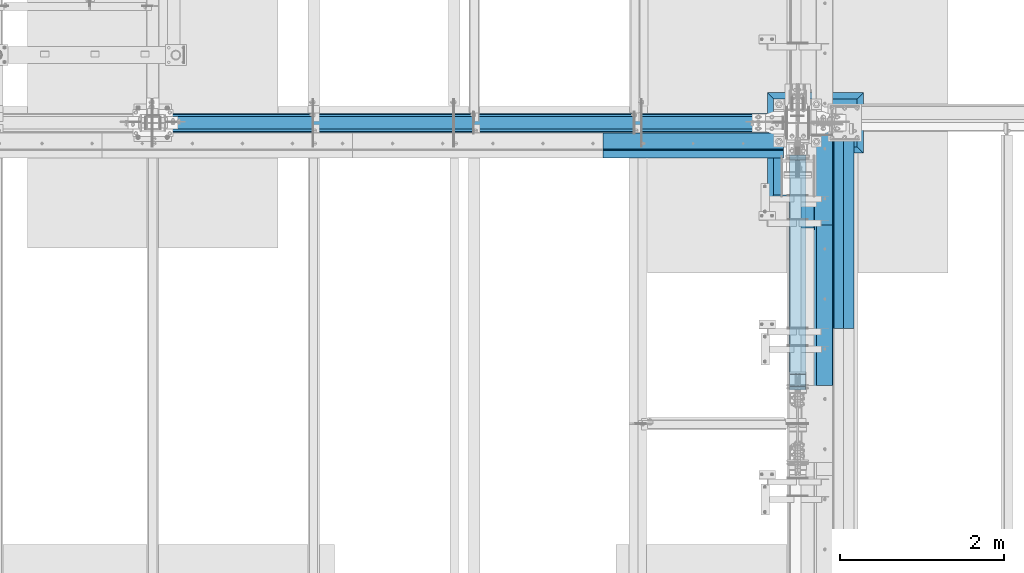
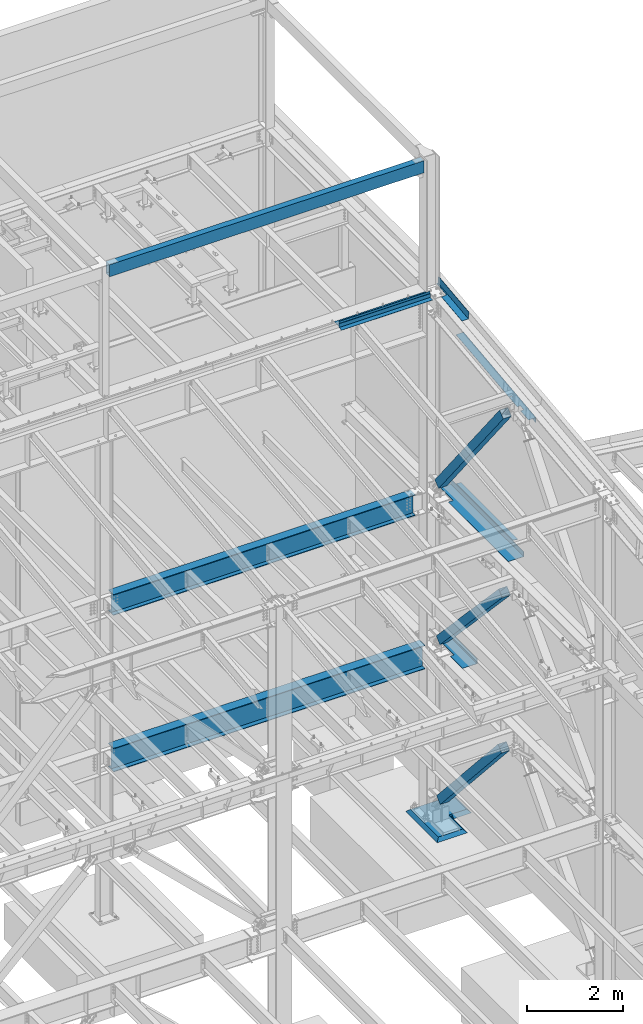
# One storey, part 775 of 1179: 12 beams, 3 members, 14 elements without a shape of their own.
"""IFC2X3 building model written with IfcOpenShell, lengths in millimetres."""

from ifc_helpers import new_model, si_unit, frame, origin_with_axes, place, context, subcontext, project, spatial, faceted_brep, material, type_object, element, aggregate, save


model = new_model("IFC2X3")

# Units and contexts
model_context = context("Model", 3, precision=1e-05, world=origin_with_axes())
body_context = subcontext(model_context, "Body", "Model", "MODEL_VIEW")
ifc_project = project(units=[si_unit("LENGTHUNIT", "METRE", prefix="MILLI"), si_unit("AREAUNIT", "SQUARE_METRE"), si_unit("VOLUMEUNIT", "CUBIC_METRE"), si_unit("MASSUNIT", "GRAM", prefix="KILO"), si_unit("TIMEUNIT", "SECOND"), si_unit("PLANEANGLEUNIT", "RADIAN"), si_unit("SOLIDANGLEUNIT", "STERADIAN"), si_unit("THERMODYNAMICTEMPERATUREUNIT", "DEGREE_CELSIUS"), si_unit("LUMINOUSINTENSITYUNIT", "LUMEN")], contexts=[model_context])

# Site, building, storey
site_placement = place(None, origin_with_axes())
site = spatial("IfcSite", under=ifc_project, at=site_placement, CompositionType="ELEMENT")
building_placement = place(site_placement, origin_with_axes())
building = spatial("IfcBuilding", under=site, at=building_placement, Name="Undefined", CompositionType="ELEMENT")
storey_placement = place(building_placement, origin_with_axes())
storey = spatial("IfcBuildingStorey", under=building, at=storey_placement, Name="Undefined", CompositionType="ELEMENT", Elevation=0.0)

# Assembly, beam
assembly_1_placement = place(storey_placement, origin_with_axes())
assembly_1 = element("IfcElementAssembly", 1, at=assembly_1_placement, inside=storey, Name="BEAM", AssemblyPlace="NOTDEFINED", PredefinedType="RIGID_FRAME")
ifc_material_1 = material(Name="STEEL/A36")
beam_type_1 = type_object("IfcBeamType", PredefinedType="NOTDEFINED")
beam_1_placement = place(assembly_1_placement, frame((24350.6630000112, 33750.8239309392, 13063.8736849896), z_axis=(0.0, -0.993676146336441, -0.112284087038017), x_axis=(1.0, 0.0, 0.0)))
beam_1 = element("IfcBeam", 2, at=beam_1_placement, type_object=beam_type_1, material=ifc_material_1, Name="BENT_PLATE", context=body_context, shape_type="Brep", body=[
    faceted_brep([(125.411064157626, -3.25796124146109, -222.2233852844), (125.411083925232, 3.17499999981919, -222.223388638246), (125.411548813434, 3.1749999994754, -643.731500001937), (125.411529045858, -3.17500000052132, -643.731500001937), (5.14432940690313e-11, -3.17499999981919, -222.223406928701), (5.14432940690313e-11, 3.17500000017753, -222.223410238686), (153.98699999888, 3.17500000052314, 643.731500002003), (-1.48986600834178e-10, 3.17499999947358, 643.731500001959), (-1.48986600834178e-10, -3.17500000052314, 643.731500001952), (160.336999998879, -3.17499999947358, 643.73150000201), (160.336999999035, 187.325000001743, 643.731500001973), (153.986999999037, 187.325000001743, 643.731500001973), (153.986999999484, 3.1749999994754, -643.73150000193), (153.986999999328, 187.325000000987, -643.731500001966), (160.336999999327, 187.325000000988, -643.731500001959), (160.336999999483, -3.17500000052132, -643.73150000193)], [[[0, 1, 2, 3]], [[4, 5, 1, 0]], [[6, 7, 8, 9, 10, 11]], [[12, 6, 11, 13]], [[10, 14, 13, 11]], [[9, 15, 14, 10]], [[12, 13, 14, 15, 3, 2]], [[7, 6, 12, 2, 1, 5]], [[8, 7, 5, 4]], [[15, 9, 8, 4, 0, 3]]]),
])

assembly_2_placement = place(storey_placement, origin_with_axes())
assembly_2 = element("IfcElementAssembly", 3, at=assembly_2_placement, inside=storey, Name="BENT_PLATE", AssemblyPlace="NOTDEFINED", PredefinedType="RIGID_FRAME")
beam_type_2 = type_object("IfcBeamType", PredefinedType="NOTDEFINED")
beam_2_placement = place(assembly_2_placement, frame((23035.4190008895, 34061.4000000804, 13197.7319337816), z_axis=(1.0, 0.0, 0.0), x_axis=(0.0, 0.0, -1.0)))
beam_2 = element("IfcBeam", 4, at=beam_2_placement, type_object=beam_type_2, material=ifc_material_1, Name="BENT_PLATE", context=body_context, shape_type="Brep", body=[
    faceted_brep([(0.0, -3.17500000000291, -1097.7565), (0.0, -3.17500000000291, 1097.7565), (0.0, 3.17500000000291, 1097.7565), (0.0, 3.17500000000291, -1097.7565), (101.600000000008, 3.17500000000291, 1097.7565), (101.600000000008, 3.17500000000291, -1097.7565), (95.9271295501203, -3.17500000000291, -1097.7565), (95.9271295501203, -3.17500000000291, 1097.7565), (113.008063243067, -97.782496467953, 1097.7565), (113.008063243067, -97.782496467953, -1097.7565), (106.69821971383, -98.4955004206495, 1097.7565), (106.69821971383, -98.4955004206495, -1097.7565)], [[[0, 1, 2, 3]], [[3, 2, 4, 5]], [[1, 0, 6, 7]], [[5, 4, 8, 9]], [[4, 2, 1, 7, 10, 8]], [[7, 6, 11, 10]], [[6, 0, 3, 5, 9, 11]], [[10, 11, 9, 8]]]),
])
aggregate(assembly_2, [beam_2])

# Assembly, member
assembly_3_placement = place(storey_placement, origin_with_axes())
assembly_3 = element("IfcElementAssembly", 5, at=assembly_3_placement, inside=storey, Name="None", AssemblyPlace="NOTDEFINED", PredefinedType="RIGID_FRAME")
ifc_material_2 = material(Name="STEEL/A992")
member_type = type_object("IfcMemberType", Name="HSS8X8X3/16", PredefinedType="NOTDEFINED")
member_1_placement = place(assembly_3_placement, frame((24307.8, 33919.5160674255, 8400.67903827649), z_axis=(-1.0, 0.0, 0.0), x_axis=(0.0, -0.620566998242277, 0.784153429306134)))
member_1 = element("IfcMember", 6, at=member_1_placement, type_object=member_type, material=ifc_material_2, Name="None", ObjectType="HSS8X8X3/16", context=body_context, shape_type="Brep", body=[
    faceted_brep([(-3.63797880709171e-12, 96.8374999999978, -96.8375000000015), (-3.63797880709171e-12, -96.8374999999978, -96.8375000000015), (4352.29000005135, -96.8374999959742, -96.8375), (4352.2900000514, 96.8375000037995, -96.8375), (-3.63797880709171e-12, -96.8374999999978, 96.8375000000015), (4352.29000005135, -96.8374999959742, 96.8375), (-3.63797880709171e-12, 96.8374999999978, 96.8375000000015), (4352.2900000514, 96.8375000037995, 96.8375), (-3.63797880709171e-12, 101.599999999999, -101.599999999999), (-3.63797880709171e-12, 101.599999999999, 101.599999999999), (4352.2900000514, 101.600000003793, 101.6), (4352.2900000514, 101.600000003793, -101.6), (0.0, -101.599999999999, 101.599999999999), (4352.29000005135, -101.599999995971, 101.6), (0.0, -101.599999999999, -101.599999999999), (4352.29000005135, -101.599999995971, -101.6)], [[[0, 1, 2, 3]], [[1, 4, 5, 2]], [[4, 6, 7, 5]], [[6, 0, 3, 7]], [[8, 9, 10, 11]], [[9, 12, 13, 10]], [[12, 14, 15, 13]], [[14, 8, 11, 15]], [[13, 15, 11, 10], [5, 7, 3, 2]], [[14, 12, 9, 8], [6, 4, 1, 0]]]),
])
aggregate(assembly_3, [member_1])

assembly_4_placement = place(storey_placement, origin_with_axes())
assembly_4 = element("IfcElementAssembly", 7, at=assembly_4_placement, inside=storey, Name="None", AssemblyPlace="NOTDEFINED", PredefinedType="RIGID_FRAME")
member_2_placement = place(assembly_4_placement, frame((24307.8, 33864.8365894738, 4453.94491513626), z_axis=(-1.0, 0.0, 0.0), x_axis=(0.0, -0.684256097894612, 0.729241792887681)))
member_2 = element("IfcMember", 8, at=member_2_placement, type_object=member_type, material=ifc_material_2, Name="None", ObjectType="HSS8X8X3/16", context=body_context, shape_type="Brep", body=[
    faceted_brep([(-3.63797880709171e-12, 96.8374999999978, -96.8375000000015), (-3.63797880709171e-12, -96.8374999999978, -96.8375000000015), (3806.84458407234, -96.837499991303, -96.8375), (3806.84458407192, 96.8375000092055, -96.8375), (-3.63797880709171e-12, -96.8374999999978, 96.8375000000015), (3806.84458407234, -96.837499991303, 96.8375), (-3.63797880709171e-12, 96.8374999999978, 96.8375000000015), (3806.84458407192, 96.8375000092055, 96.8375), (-3.63797880709171e-12, 101.599999999999, -101.599999999999), (-3.63797880709171e-12, 101.599999999999, 101.599999999999), (3806.84458407191, 101.600000009224, 101.6), (3806.84458407191, 101.600000009224, -101.6), (0.0, -101.599999999999, 101.599999999999), (3806.84458407235, -101.599999991318, 101.6), (0.0, -101.599999999999, -101.599999999999), (3806.84458407235, -101.599999991318, -101.6)], [[[0, 1, 2, 3]], [[1, 4, 5, 2]], [[4, 6, 7, 5]], [[6, 0, 3, 7]], [[8, 9, 10, 11]], [[9, 12, 13, 10]], [[12, 14, 15, 13]], [[14, 8, 11, 15]], [[13, 15, 11, 10], [5, 7, 3, 2]], [[14, 12, 9, 8], [6, 4, 1, 0]]]),
])
aggregate(assembly_4, [member_2])

assembly_5_placement = place(storey_placement, origin_with_axes())
assembly_5 = element("IfcElementAssembly", 9, at=assembly_5_placement, inside=storey, Name="None", AssemblyPlace="NOTDEFINED", PredefinedType="RIGID_FRAME")
member_3_placement = place(assembly_5_placement, frame((24307.8, 33849.8816976666, 390.487097634389), z_axis=(-1.0, 0.0, 0.0), x_axis=(0.0, -0.666221892712435, 0.745753571678112)))
member_3 = element("IfcMember", 10, at=member_3_placement, type_object=member_type, material=ifc_material_2, Name="None", ObjectType="HSS8X8X3/16", context=body_context, shape_type="Brep", body=[
    faceted_brep([(-3.63797880709171e-12, 96.8374999999978, -96.8375000000015), (-3.63797880709171e-12, -96.8374999999978, -96.8375000000015), (3848.73500006714, -96.837500009533, -96.8375000000015), (3848.73500006755, 96.8374999900007, -96.8375000000015), (-3.63797880709171e-12, -96.8374999999978, 96.8375000000015), (3848.73500006714, -96.837500009533, 96.8375000000015), (-3.63797880709171e-12, 96.8374999999978, 96.8375000000015), (3848.73500006755, 96.8374999900007, 96.8375000000015), (-3.63797880709171e-12, 101.599999999999, -101.599999999999), (-3.63797880709171e-12, 101.599999999999, 101.599999999999), (3848.73500006757, 101.599999989987, 101.599999999999), (3848.73500006757, 101.599999989987, -101.599999999999), (0.0, -101.599999999999, 101.599999999999), (3848.73500006713, -101.600000009519, 101.599999999999), (0.0, -101.599999999999, -101.599999999999), (3848.73500006713, -101.600000009519, -101.599999999999)], [[[0, 1, 2, 3]], [[1, 4, 5, 2]], [[4, 6, 7, 5]], [[6, 0, 3, 7]], [[8, 9, 10, 11]], [[9, 12, 13, 10]], [[12, 14, 15, 13]], [[14, 8, 11, 15]], [[13, 15, 11, 10], [5, 7, 3, 2]], [[14, 12, 9, 8], [6, 4, 1, 0]]]),
])
aggregate(assembly_5, [member_3])

# Assembly, beam
assembly_6_placement = place(storey_placement, origin_with_axes())
assembly_6 = element("IfcElementAssembly", 11, at=assembly_6_placement, inside=storey, Name="BEAM", AssemblyPlace="NOTDEFINED", PredefinedType="RIGID_FRAME")
beam_type_3 = type_object("IfcBeamType", PredefinedType="NOTDEFINED")
beam_3_placement = place(assembly_6_placement, frame((23035.4190008164, 34267.775, 13122.275), z_axis=(1.0, 0.0, 0.0), x_axis=(0.0, -1.0, 0.0)))
beam_3 = element("IfcBeam", 12, at=beam_3_placement, type_object=beam_type_3, material=ifc_material_1, Name="BENT_PLATE", context=body_context, shape_type="Brep", body=[
    faceted_brep([(0.0, -3.17500000000291, -1097.7565), (0.0, -3.17500000000291, 1097.7565), (0.0, 3.17500000000291, 1097.7565), (0.0, 3.17500000000291, -1097.7565), (203.199999999997, 3.17499999999927, 1097.7565), (203.199999999997, 3.17499999999927, -1097.7565), (196.849999999991, -3.17499999999927, -1097.7565), (196.849999999991, -3.17499999999927, 1097.7565), (203.199999999997, -130.175000000001, 1097.7565), (203.199999999997, -130.175000000001, -1097.7565), (196.849999999991, -130.175000000001, 1097.7565), (196.849999999991, -130.175000000001, -1097.7565)], [[[0, 1, 2, 3]], [[3, 2, 4, 5]], [[1, 0, 6, 7]], [[5, 4, 8, 9]], [[4, 2, 1, 7, 10, 8]], [[7, 6, 11, 10]], [[6, 0, 3, 5, 9, 11]], [[10, 11, 9, 8]]]),
])
aggregate(assembly_6, [beam_3])

# Beam
beam_type_4 = type_object("IfcBeamType", PredefinedType="NOTDEFINED")
beam_4_placement = place(assembly_1_placement, frame((24350.6629998545, 31854.7938429563, 12320.8188205843), z_axis=(0.0, -0.993676146336441, -0.112284087038017), x_axis=(1.0, 0.0, 0.0)))
beam_4 = element("IfcBeam", 13, at=beam_4_placement, type_object=beam_type_4, material=ifc_material_1, Name="BENT_PLATE", context=body_context, shape_type="Brep", body=[
    faceted_brep([(76.199500145096, -3.17463485857479, 694.419031011836), (76.199500145096, 3.17597875524552, 694.419031011839), (0.0, 3.17500000028122, 694.419031011839), (0.0, -3.17499999971551, 694.419031011832), (76.199500145096, -3.1746348585657, 710.294031011672), (76.199500145096, 3.17597875524916, 710.29403101165), (0.0, -3.17499999971005, 710.294031011672), (0.0, 3.17500000028667, 710.29403101165), (76.1995001455398, -3.17561372409182, 1051.51788982289), (76.1995001455398, 3.17499988972304, 1051.5178898197), (0.0, 3.17500000042492, 1051.5178898197), (0.0, -3.17499999956999, 1051.51788982289), (76.1995001455398, -3.17561329085038, 1191.55451282355), (76.1995001455398, 3.17500032295538, 1191.55451282033), (0.0, -3.17499999951542, 1191.55451282355), (0.0, 3.1750000004813, 1191.55451282033), (6.00266503170133e-10, -3.17499999922438, 1524.00000000052), (6.00266503170133e-10, 3.17500000077416, 1524.00000000052), (179.387000000001, -3.17499999999927, 1524.0), (179.387000000001, -3.17499999999927, -1524.0), (179.387000202249, -136.524999793119, -1523.99999999991), (179.38700020294, -136.524999792508, 1523.99999999976), (185.737000000001, 3.17499999999927, 1524.0), (185.737000202938, -136.524999792508, 1523.99999999976), (185.737000000001, 3.17499999999927, -1524.0), (185.737000202247, -136.524999793119, -1523.99999999991), (0.0, -3.17499999999927, -1524.0), (0.0, 3.17499999999927, -1524.0)], [[[0, 1, 2, 3]], [[4, 5, 1, 0]], [[6, 7, 5, 4]], [[8, 9, 10, 11]], [[12, 13, 9, 8]], [[14, 15, 13, 12]], [[16, 17, 15, 14]], [[18, 19, 20, 21]], [[22, 17, 16, 18, 21, 23]], [[24, 22, 23, 25]], [[21, 20, 25, 23]], [[19, 26, 27, 24, 25, 20]], [[27, 26, 3, 2]], [[10, 9, 13, 15, 17, 22, 24, 27, 2, 1, 5, 7]], [[11, 10, 7, 6]], [[3, 26, 19, 18, 16, 14, 12, 8, 11, 6, 4, 0]]]),
])

aggregate(assembly_1, [beam_1, beam_4])

# Assembly, beam
assembly_7_placement = place(storey_placement, origin_with_axes())
assembly_7 = element("IfcElementAssembly", 14, at=assembly_7_placement, inside=storey, Name="PLATE", AssemblyPlace="NOTDEFINED", PredefinedType="RIGID_FRAME")
beam_type_5 = type_object("IfcBeamType", PredefinedType="NOTDEFINED")
beam_5_placement = place(assembly_7_placement, frame((24880.9652345644, 31889.6999999996, 7964.0487255808), z_axis=(-0.99100656978554, 0.0, 0.133813222971043), x_axis=(0.0, 1.0, 0.0)))
beam_5 = element("IfcBeam", 15, at=beam_5_placement, type_object=beam_type_5, material=ifc_material_1, Name="PLATE", context=body_context, shape_type="Brep", body=[
    faceted_brep([(0.0, 4.76249999999709, -114.3), (0.0, 4.76249999999709, 114.3), (2383.63125000036, 4.76249999996799, 114.300000000025), (2383.63125000036, 4.76250000002983, -114.300000000025), (0.0, -4.76249999999709, 114.3), (2383.63125000036, -4.76250000003711, 114.300000000014), (0.0, -4.76249999999709, -114.3), (2383.63125000036, -4.76249999997344, -114.300000000036)], [[[0, 1, 2, 3]], [[1, 4, 5, 2]], [[4, 6, 7, 5]], [[6, 0, 3, 7]], [[5, 7, 3, 2]], [[6, 4, 1, 0]]]),
])
aggregate(assembly_7, [beam_5])

assembly_8_placement = place(storey_placement, origin_with_axes())
assembly_8 = element("IfcElementAssembly", 16, at=assembly_8_placement, inside=storey, Name="BEAM", AssemblyPlace="NOTDEFINED", PredefinedType="RIGID_FRAME")
beam_type_6 = type_object("IfcBeamType", PredefinedType="NOTDEFINED")
beam_6_placement = place(assembly_8_placement, frame((24387.175012207, 33769.3005, 4105.275), z_axis=(0.0, -1.0, 0.0), x_axis=(1.0, 0.0, 0.0)))
beam_6 = element("IfcBeam", 17, at=beam_6_placement, type_object=beam_type_6, material=ifc_material_1, Name="BENT_PLATE", context=body_context, shape_type="Brep", body=[
    faceted_brep([(88.8999862670898, -3.17500000000018, 103.408503422921), (88.8999862670898, 3.17500000000018, 103.408503422921), (88.8999862670898, 3.17500000000018, -619.125), (88.8999862670898, -3.17500000000018, -619.125), (0.0, -3.17500000000018, 103.408503422921), (0.0, 3.17500000000018, 103.408503422921), (346.07498779297, 3.17500000000109, 619.125), (0.0, 3.17500000000018, 619.125), (0.0, -3.17500000000018, 619.125), (352.424987792969, -3.17499999999927, 619.125), (352.424987792969, 130.175006103515, 619.125), (346.07498779297, 130.175006103515, 619.125), (346.07498779297, 3.17500000000109, -619.125), (346.07498779297, 130.175006103515, -619.125), (352.424987792969, 130.175006103515, -619.125), (352.424987792969, -3.17499999999927, -619.125)], [[[0, 1, 2, 3]], [[4, 5, 1, 0]], [[6, 7, 8, 9, 10, 11]], [[12, 6, 11, 13]], [[10, 14, 13, 11]], [[9, 15, 14, 10]], [[12, 13, 14, 15, 3, 2]], [[7, 6, 12, 2, 1, 5]], [[8, 7, 5, 4]], [[15, 9, 8, 4, 0, 3]]]),
])
aggregate(assembly_8, [beam_6])

assembly_9_placement = place(storey_placement, origin_with_axes())
assembly_9 = element("IfcElementAssembly", 18, at=assembly_9_placement, inside=storey, Name="BEAM", AssemblyPlace="NOTDEFINED", PredefinedType="RIGID_FRAME")
beam_type_7 = type_object("IfcBeamType", PredefinedType="NOTDEFINED")
beam_7_placement = place(assembly_9_placement, frame((24361.7749941007, 32721.5499996401, 8018.4625), z_axis=(0.0, 1.0, 0.0), x_axis=(1.0, 0.0, 0.0)))
beam_7 = element("IfcBeam", 19, at=beam_7_placement, type_object=beam_type_7, material=ifc_material_1, Name="BENT_PLATE", context=body_context, shape_type="Brep", body=[
    faceted_brep([(114.30000519731, -4.76249998240564, 978.516176814912), (114.300005349709, 4.76250001759399, 978.516176814912), (-1.60434865392745e-09, 4.76249999999982, 978.516177091326), (-1.38243194669485e-10, -4.76249999999982, 978.516177091326), (114.300008613136, -4.76249998240564, 1523.9999999459), (114.300008765535, 4.76250001759399, 1524.0000000001), (368.300003074455, -4.76249994330828, -1523.99999999967), (-2.91038304567337e-11, -4.76250000000073, -1524.0), (2.91038304567337e-11, 4.76250000000073, -1524.0), (377.825003226844, 4.76250005815837, -1523.99999999966), (377.82500109337, -128.587512295235, -1523.99999999966), (368.300001093368, -128.587512142843, -1523.99999999967), (377.825003224127, 4.76250005815837, 1524.00000000034), (377.825001090652, -128.587512295235, 1524.00000000034), (368.300001090651, -128.587512142843, 1524.00000000033), (368.300003071738, -4.76249994330828, 1524.00000000033)], [[[0, 1, 2, 3]], [[4, 5, 1, 0]], [[6, 7, 8, 9, 10, 11]], [[9, 12, 13, 10]], [[14, 11, 10, 13]], [[15, 6, 11, 14]], [[3, 7, 6, 15, 4, 0]], [[8, 7, 3, 2]], [[12, 9, 8, 2, 1, 5]], [[15, 14, 13, 12, 5, 4]]]),
])
aggregate(assembly_9, [beam_7])

assembly_10_placement = place(storey_placement, origin_with_axes())
assembly_10 = element("IfcElementAssembly", 20, at=assembly_10_placement, inside=storey, Name="BENT_PLATE", AssemblyPlace="NOTDEFINED", PredefinedType="RIGID_FRAME")
beam_type_8 = type_object("IfcBeamType", PredefinedType="NOTDEFINED")
beam_8_placement = place(assembly_10_placement, frame((24744.362499997, 33081.9124999997, 8102.29217706157), z_axis=(0.0, 1.0, 0.0), x_axis=(0.0, 0.0, -1.0)))
beam_8 = element("IfcBeam", 21, at=beam_8_placement, type_object=beam_type_8, material=ifc_material_1, Name="BENT_PLATE", context=body_context, shape_type="Brep", body=[
    faceted_brep([(2.45563569478691e-11, -4.76250000000073, -1192.2125), (2.45563569478691e-11, -4.76250000000073, 1192.2125), (-2.45563569478691e-11, 4.76250000000073, 1192.2125), (-2.45563569478691e-11, 4.76250000000073, -1192.2125), (114.300003051474, 4.7625000005828, 1192.2125), (114.300003051474, 4.7625000005828, -1192.2125), (105.977955544956, -4.76249999945867, -1192.2125), (105.977955544956, -4.76249999945867, 1192.2125), (131.343048095475, -121.088742065571, 1192.2125), (131.343048095475, -121.088742065571, -1192.2125), (121.904205090902, -122.366970423507, 1192.2125), (121.904205090902, -122.366970423507, -1192.2125)], [[[0, 1, 2, 3]], [[3, 2, 4, 5]], [[1, 0, 6, 7]], [[5, 4, 8, 9]], [[4, 2, 1, 7, 10, 8]], [[7, 6, 11, 10]], [[6, 0, 3, 5, 9, 11]], [[10, 11, 9, 8]]]),
])
aggregate(assembly_10, [beam_8])

assembly_11_placement = place(storey_placement, origin_with_axes())
assembly_11 = element("IfcElementAssembly", 22, at=assembly_11_placement, inside=storey, Name="BEAM", AssemblyPlace="NOTDEFINED", PredefinedType="RIGID_FRAME")
ifc_material_3 = material()
beam_type_9 = type_object("IfcBeamType", Name="HSS12X6X3/8", PredefinedType="NOTDEFINED")
beam_9_placement = place(assembly_11_placement, frame((16548.1, 34391.6, 16275.05), z_axis=(0.0, 0.0, 1.0), x_axis=(1.0, 0.0, 0.0)))
beam_9 = element("IfcBeam", 23, at=beam_9_placement, type_object=beam_type_9, material=ifc_material_3, Name="BEAM", ObjectType="HSS12X6X3/8", context=body_context, shape_type="Brep", body=[
    faceted_brep([(4.76249999999709, 66.6749999999993, -142.875), (4.76249999999709, -66.6749999999993, -142.875), (7580.31250005722, -66.6750000000029, -142.875), (7580.31250005722, 66.6750000000029, -142.875), (4.76249999999709, -66.6749999999993, 142.875000000002), (7580.31250005722, -66.6750000000029, 142.875000000002), (4.76249999999709, 66.6749999999993, 142.875000000002), (7580.31250005722, 66.6750000000029, 142.875000000002), (4.76249999999709, 76.2000000000007, -152.4), (4.76249999999709, 76.2000000000007, 152.4), (7580.31250005722, 76.1999999999971, 152.4), (7580.31250005722, 76.1999999999971, -152.4), (4.76249999999709, -76.2000000000007, 152.4), (7580.31250005722, -76.1999999999971, 152.4), (4.76249999999709, -76.2000000000007, -152.4), (7580.31250005722, -76.1999999999971, -152.4)], [[[0, 1, 2, 3]], [[1, 4, 5, 2]], [[4, 6, 7, 5]], [[6, 0, 3, 7]], [[8, 9, 10, 11]], [[9, 12, 13, 10]], [[12, 14, 15, 13]], [[14, 8, 11, 15]], [[13, 15, 11, 10], [5, 7, 3, 2]], [[14, 12, 9, 8], [6, 4, 1, 0]]]),
])
aggregate(assembly_11, [beam_9])

assembly_12_placement = place(storey_placement, origin_with_axes())
assembly_12 = element("IfcElementAssembly", 24, at=assembly_12_placement, inside=storey, Name="BEAM", AssemblyPlace="NOTDEFINED", PredefinedType="RIGID_FRAME")
beam_type_10 = type_object("IfcBeamType", Name="W21X62", PredefinedType="NOTDEFINED")
beam_10_placement = place(assembly_12_placement, frame((16459.2, 34391.6, 7747.0), z_axis=(0.0, 0.0, 1.0), x_axis=(1.0, 0.0, 0.0)))
beam_10 = element("IfcBeam", 25, at=beam_10_placement, type_object=beam_type_10, material=ifc_material_2, Name="BEAM", ObjectType="W21X62", context=body_context, shape_type="Brep", body=[
    faceted_brep([(168.275000000001, -104.775000000001, -266.7), (168.275000000001, 104.775000000001, -266.7), (7445.375, 104.775000000001, -266.7), (7445.375, -104.775000000001, -266.7), (168.275000000001, -104.775000000001, -250.825), (168.275000000001, -4.76249999999709, -250.825), (168.275000000001, -4.76249999999709, 250.825), (168.275000000001, -104.775000000001, 250.825), (168.275000000001, -104.775000000001, 266.7), (168.275000000001, 104.775000000001, 266.7), (168.275000000001, 104.775000000001, 250.825), (168.275000000001, 4.76249999999709, 250.825), (168.275000000001, 4.76249999999709, -250.825), (168.275000000001, 104.775000000001, -250.825), (7445.375, -104.775000000001, -250.825), (7445.375, -4.76249999999709, -250.825), (7445.375, -4.76249999999709, 250.825), (7445.375, -104.775000000001, 250.825), (7445.375, -104.775000000001, 266.7), (7445.375, 104.775000000001, 266.7), (7445.375, 104.775000000001, 250.825), (7445.375, 4.76249999999709, 250.825), (7445.375, 4.76249999999709, -250.825), (7445.375, 104.775000000001, -250.825)], [[[0, 1, 2, 3]], [[0, 4, 5, 6, 7, 8, 9, 10, 11, 12, 13, 1]], [[5, 4, 14, 15]], [[6, 5, 15, 16]], [[7, 6, 16, 17]], [[8, 7, 17, 18]], [[9, 8, 18, 19]], [[10, 9, 19, 20]], [[11, 10, 20, 21]], [[12, 11, 21, 22]], [[13, 12, 22, 23]], [[1, 13, 23, 2]], [[22, 21, 20, 19, 18, 17, 16, 15, 14, 3, 2, 23]], [[4, 0, 3, 14]]]),
])
aggregate(assembly_12, [beam_10])

assembly_13_placement = place(storey_placement, origin_with_axes())
assembly_13 = element("IfcElementAssembly", 26, at=assembly_13_placement, inside=storey, Name="BEAM", AssemblyPlace="NOTDEFINED", PredefinedType="RIGID_FRAME")
beam_type_11 = type_object("IfcBeamType", Name="W24X68", PredefinedType="NOTDEFINED")
beam_11_placement = place(assembly_13_placement, frame((16459.2, 34391.6, 3800.475), z_axis=(0.0, 0.0, 1.0), x_axis=(1.0, 0.0, 0.0)))
beam_11 = element("IfcBeam", 27, at=beam_11_placement, type_object=beam_type_11, material=ifc_material_2, Name="BEAM", ObjectType="W24X68", context=body_context, shape_type="Brep", body=[
    faceted_brep([(168.275000000001, -114.300000000003, -301.625), (168.275000000001, 114.300000000003, -301.625), (7673.975, 114.300000000003, -301.625), (7673.975, -114.300000000003, -301.625), (168.275000000001, -114.300000000003, -287.3375), (168.275000000001, -5.55625000000146, -287.3375), (168.275000000001, -5.55625000000146, 287.3375), (168.275000000001, -114.300000000003, 287.3375), (168.275000000001, -114.300000000003, 301.625), (168.275000000001, 114.300000000003, 301.625), (168.275000000001, 114.300000000003, 287.3375), (168.275000000001, 5.55625000000146, 287.3375), (168.275000000001, 5.55625000000146, -287.3375), (168.275000000001, 114.300000000003, -287.3375), (7673.975, -114.300000000003, -287.3375), (7673.975, -5.55625000000146, -287.3375), (7673.975, -5.55625000000146, 287.3375), (7673.975, -114.300000000003, 287.3375), (7673.975, -114.300000000003, 301.625), (7673.975, 114.300000000003, 301.625), (7673.975, 114.300000000003, 287.3375), (7673.975, 5.55625000000146, 287.3375), (7673.975, 5.55625000000146, -287.3375), (7673.975, 114.300000000003, -287.3375)], [[[0, 1, 2, 3]], [[0, 4, 5, 6, 7, 8, 9, 10, 11, 12, 13, 1]], [[5, 4, 14, 15]], [[6, 5, 15, 16]], [[7, 6, 16, 17]], [[8, 7, 17, 18]], [[9, 8, 18, 19]], [[10, 9, 19, 20]], [[11, 10, 20, 21]], [[12, 11, 21, 22]], [[13, 12, 22, 23]], [[1, 13, 23, 2]], [[22, 21, 20, 19, 18, 17, 16, 15, 14, 3, 2, 23]], [[4, 0, 3, 14]]]),
])
aggregate(assembly_13, [beam_11])

assembly_14_placement = place(storey_placement, origin_with_axes())
assembly_14 = element("IfcElementAssembly", 28, at=assembly_14_placement, inside=storey, Name="GROUT", AssemblyPlace="NOTDEFINED", PredefinedType="REINFORCEMENT_UNIT")
ifc_material_4 = material(Name="CONCRETE/Concrete_Undefined")
beam_type_12 = type_object("IfcBeamType", PredefinedType="NOTDEFINED")
beam_12_placement = place(assembly_14_placement, frame((25107.8999999998, 34391.6, -317.5), z_axis=(0.0, -1.0, 0.0), x_axis=(-1.0, 0.0, 0.0)))
beam_12 = element("IfcBeam", 29, at=beam_12_placement, type_object=beam_type_12, material=ifc_material_4, Name="GROUT", context=body_context, shape_type="Brep", body=[
    faceted_brep([(507.999987792969, -38.0999969482422, 292.100003051746), (507.999987792969, 38.1, 368.299999999988), (431.799975585938, 38.1, 368.299999999988), (507.999987792969, -38.0999969482422, 368.299999999988), (-2.18278728425503e-11, 38.1, 368.300000000003), (76.1999969482604, -38.0999972639412, 292.100003051746), (431.799975585938, -38.0999969482422, 292.100003051746), (431.799975585938, 38.1, 292.100003051746), (76.1999969482604, -38.0999996843007, -292.09993147885), (2.18278728425503e-11, 38.1, -368.300000000003), (1168.39997558594, 38.1, -368.299999999923), (1092.19996337889, -38.09999713913, -292.100094037123), (1168.39997558592, 38.0999999999581, 952.499882071555), (1092.19996337889, -38.1, 876.299971552871), (431.799975585938, 38.1, 952.5), (507.999987792969, -38.0999969482422, 876.300065023876)], [[[0, 1, 2]], [[3, 1, 0]], [[2, 1, 3]], [[2, 4, 5, 6]], [[7, 2, 6]], [[0, 7, 6]], [[7, 0, 2]], [[8, 9, 10, 11]], [[12, 13, 11, 10]], [[13, 12, 14, 15]], [[15, 14, 2, 3]], [[6, 5, 8, 11, 13, 15, 3, 0]], [[9, 8, 5, 4]], [[14, 12, 10, 9, 4, 2]]]),
])
aggregate(assembly_14, [beam_12])

save(model, "model.ifc")
